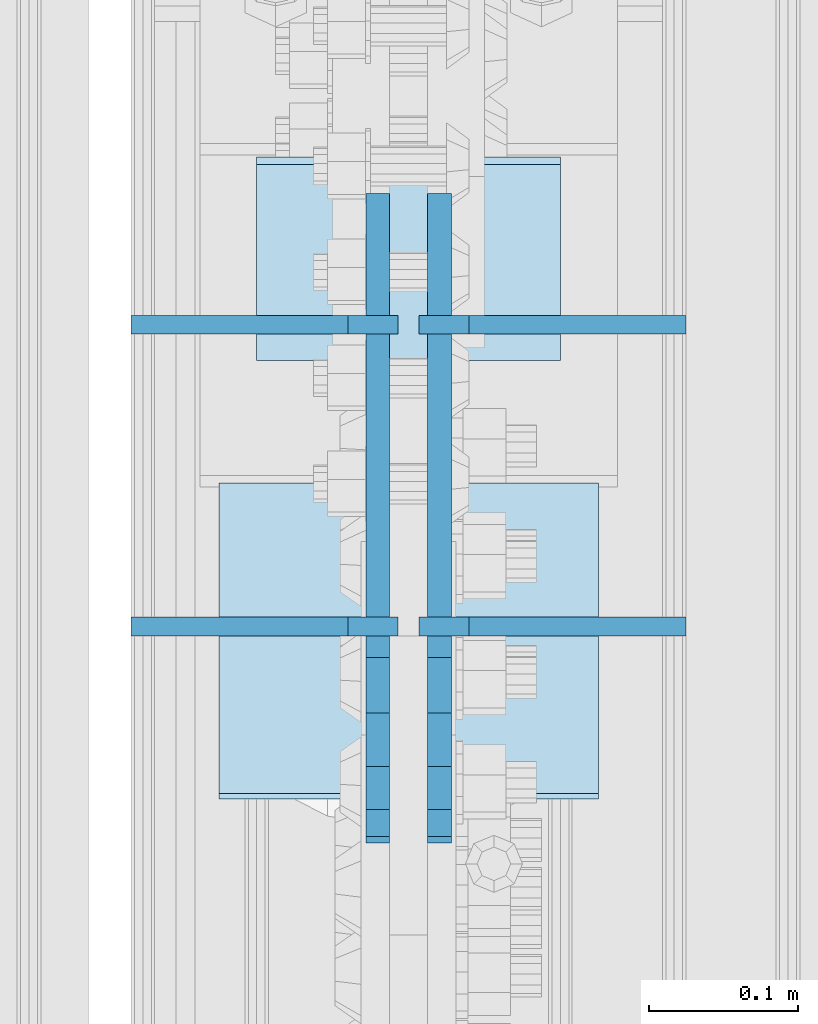
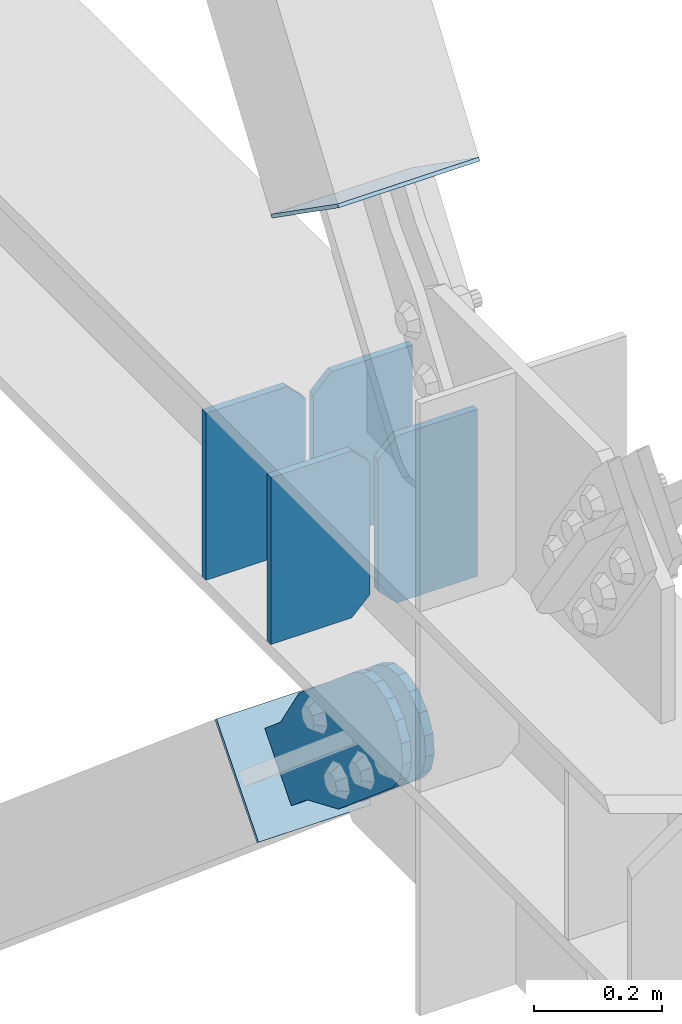
# One storey, part 3574 of 3843: 8 plates, 5 elements without a shape of their own.
"""IFC2X3 building model written with IfcOpenShell, lengths in millimetres."""

from ifc_helpers import new_model, si_unit, frame, origin_with_axes, place, context, subcontext, project, spatial, faceted_brep, material, type_object, element, aggregate, save


model = new_model("IFC2X3")

# Units and contexts
model_context = context("Model", 3, precision=1e-05, world=origin_with_axes())
body_context = subcontext(model_context, "Body", "Model", "MODEL_VIEW")
ifc_project = project(units=[si_unit("LENGTHUNIT", "METRE", prefix="MILLI"), si_unit("AREAUNIT", "SQUARE_METRE"), si_unit("VOLUMEUNIT", "CUBIC_METRE"), si_unit("MASSUNIT", "GRAM", prefix="KILO"), si_unit("TIMEUNIT", "SECOND"), si_unit("PLANEANGLEUNIT", "RADIAN"), si_unit("SOLIDANGLEUNIT", "STERADIAN"), si_unit("THERMODYNAMICTEMPERATUREUNIT", "DEGREE_CELSIUS"), si_unit("LUMINOUSINTENSITYUNIT", "LUMEN")], contexts=[model_context])

# Site, building, storey
site_placement = place(None, origin_with_axes())
site = spatial("IfcSite", under=ifc_project, at=site_placement, CompositionType="ELEMENT")
building_placement = place(site_placement, origin_with_axes())
building = spatial("IfcBuilding", under=site, at=building_placement, Name="Undefined", CompositionType="ELEMENT")
storey_placement = place(building_placement, origin_with_axes())
storey = spatial("IfcBuildingStorey", under=building, at=storey_placement, Name="Undefined", CompositionType="ELEMENT", Elevation=0.0)

# Assembly, plates
assembly_1_placement = place(storey_placement, origin_with_axes())
assembly_1 = element("IfcElementAssembly", 1, at=assembly_1_placement, inside=storey, Name="BEAM", AssemblyPlace="NOTDEFINED", PredefinedType="RIGID_FRAME")
ifc_material_1 = material(Name="STEEL/A572-50")
plate_type_1 = type_object("IfcPlateType", PredefinedType="NOTDEFINED")
plate_1_placement = place(assembly_1_placement, frame((85641.65625, 20972.8593750779, 34467.8), z_axis=(-1.0, 0.0, 0.0), x_axis=(0.0, 0.0, 1.0)))
plate_1 = element("IfcPlate", 2, at=plate_1_placement, type_object=plate_type_1, material=ifc_material_1, Name="CB_BEAM", context=body_context, shape_type="Brep", body=[
    faceted_brep([(0.0, -6.34999999999854, 33.3375015258789), (0.0, -6.34999999999854, 178.59375), (0.0, 6.34999999999854, 178.59375), (0.0, 6.34999999999854, 33.3375015258789), (317.499999999985, -6.34999999999854, 178.59375), (317.499999999985, 6.34999999999854, 178.59375), (317.499999999985, -6.34999999999854, 33.3375015258789), (317.499999999985, 6.34999999999854, 33.3375015258789), (284.162498474107, -6.34999999999854, 0.0), (284.162498474107, 6.34999999999854, 0.0), (33.3375015258789, -6.34999999999854, 0.0), (33.3375015258789, 6.34999999999854, 0.0)], [[[0, 1, 2, 3]], [[1, 4, 5, 2]], [[4, 6, 7, 5]], [[6, 8, 9, 7]], [[8, 10, 11, 9]], [[10, 0, 3, 11]], [[5, 7, 9, 11, 3, 2]], [[10, 8, 6, 4, 1, 0]]]),
])
plate_2_placement = place(assembly_1_placement, frame((85655.94375, 20972.8593750779, 34467.8), z_axis=(1.0, 0.0, 0.0), x_axis=(0.0, 0.0, 1.0)))
plate_2 = element("IfcPlate", 3, at=plate_2_placement, type_object=plate_type_1, material=ifc_material_1, Name="CB_BEAM", context=body_context, shape_type="Brep", body=[
    faceted_brep([(0.0, -6.34999999999854, 33.3375015258789), (0.0, -6.34999999999854, 178.59375), (0.0, 6.34999999999854, 178.59375), (0.0, 6.34999999999854, 33.3375015258789), (317.499999999985, -6.34999999999854, 178.59375), (317.499999999985, 6.34999999999854, 178.59375), (317.499999999985, -6.34999999999854, 33.3375015258789), (317.499999999985, 6.34999999999854, 33.3375015258789), (284.162498474107, -6.34999999999854, 0.0), (284.162498474107, 6.34999999999854, 0.0), (33.3375015258789, -6.34999999999854, 0.0), (33.3375015258789, 6.34999999999854, 0.0)], [[[0, 1, 2, 3]], [[1, 4, 5, 2]], [[4, 6, 7, 5]], [[6, 8, 9, 7]], [[8, 10, 11, 9]], [[10, 0, 3, 11]], [[5, 7, 9, 11, 3, 2]], [[10, 8, 6, 4, 1, 0]]]),
])
plate_3_placement = place(assembly_1_placement, frame((85641.65625, 20771.0484380779, 34467.8), z_axis=(-1.0, 0.0, 0.0), x_axis=(0.0, 0.0, 1.0)))
plate_3 = element("IfcPlate", 4, at=plate_3_placement, type_object=plate_type_1, material=ifc_material_1, Name="CB_BEAM", context=body_context, shape_type="Brep", body=[
    faceted_brep([(0.0, -6.34999999999854, 33.3375015258789), (0.0, -6.34999999999854, 178.59375), (0.0, 6.34999999999854, 178.59375), (0.0, 6.34999999999854, 33.3375015258789), (317.499999999985, -6.34999999999854, 178.59375), (317.499999999985, 6.34999999999854, 178.59375), (317.499999999985, -6.34999999999854, 33.3375015258789), (317.499999999985, 6.34999999999854, 33.3375015258789), (284.162498474107, -6.34999999999854, 0.0), (284.162498474107, 6.34999999999854, 0.0), (33.3375015258789, -6.34999999999854, 0.0), (33.3375015258789, 6.34999999999854, 0.0)], [[[0, 1, 2, 3]], [[1, 4, 5, 2]], [[4, 6, 7, 5]], [[6, 8, 9, 7]], [[8, 10, 11, 9]], [[10, 0, 3, 11]], [[5, 7, 9, 11, 3, 2]], [[10, 8, 6, 4, 1, 0]]]),
])
plate_4_placement = place(assembly_1_placement, frame((85655.94375, 20771.0484380779, 34467.8), z_axis=(1.0, 0.0, 0.0), x_axis=(0.0, 0.0, 1.0)))
plate_4 = element("IfcPlate", 5, at=plate_4_placement, type_object=plate_type_1, material=ifc_material_1, Name="CB_BEAM", context=body_context, shape_type="Brep", body=[
    faceted_brep([(0.0, -6.34999999999854, 33.3375015258789), (0.0, -6.34999999999854, 178.59375), (0.0, 6.34999999999854, 178.59375), (0.0, 6.34999999999854, 33.3375015258789), (317.499999999985, -6.34999999999854, 178.59375), (317.499999999985, 6.34999999999854, 178.59375), (317.499999999985, -6.34999999999854, 33.3375015258789), (317.499999999985, 6.34999999999854, 33.3375015258789), (284.162498474107, -6.34999999999854, 0.0), (284.162498474107, 6.34999999999854, 0.0), (33.3375015258789, -6.34999999999854, 0.0), (33.3375015258789, 6.34999999999854, 0.0)], [[[0, 1, 2, 3]], [[1, 4, 5, 2]], [[4, 6, 7, 5]], [[6, 8, 9, 7]], [[8, 10, 11, 9]], [[10, 0, 3, 11]], [[5, 7, 9, 11, 3, 2]], [[10, 8, 6, 4, 1, 0]]]),
])
aggregate(assembly_1, [plate_1, plate_2, plate_3, plate_4])

# Assembly, plate
assembly_2_placement = place(storey_placement, origin_with_axes())
assembly_2 = element("IfcElementAssembly", 6, at=assembly_2_placement, inside=storey, Name="Plate", AssemblyPlace="NOTDEFINED", PredefinedType="RIGID_FRAME")
ifc_material_2 = material(Name="STEEL/A36")
plate_type_2 = type_object("IfcPlateType", PredefinedType="NOTDEFINED")
plate_5_placement = place(assembly_2_placement, frame((85547.2, 20951.3934155147, 33948.7831890643), z_axis=(0.0, 0.645737502174365, 0.763559479206179), x_axis=(1.0, 0.0, 0.0)))
plate_5 = element("IfcPlate", 7, at=plate_5_placement, type_object=plate_type_2, material=ifc_material_2, Name="Plate", context=body_context, shape_type="Brep", body=[
    faceted_brep([(0.0, -3.17499999999927, 0.0), (0.0, -3.17500000043947, 203.200000001736), (0.0, 3.1749999995518, 203.200000001743), (0.0, 3.17499999999927, 0.0), (203.200000000012, -3.17500000043947, 203.200000001736), (203.200000000012, 3.1749999995518, 203.200000001743), (203.199996948242, -3.17499999999927, 0.0), (203.199996948242, 3.17499999999927, 0.0)], [[[0, 1, 2, 3]], [[1, 4, 5, 2]], [[4, 6, 7, 5]], [[6, 0, 3, 7]], [[5, 7, 3, 2]], [[6, 4, 1, 0]]]),
])
aggregate(assembly_2, [plate_5])

assembly_3_placement = place(storey_placement, origin_with_axes())
assembly_3 = element("IfcElementAssembly", 8, at=assembly_3_placement, inside=storey, Name="Plate", AssemblyPlace="NOTDEFINED", PredefinedType="RIGID_FRAME")
plate_type_3 = type_object("IfcPlateType", PredefinedType="NOTDEFINED")
plate_6_placement = place(assembly_3_placement, frame((85775.8, 20865.1681183892, 35200.9374941291), z_axis=(0.0, -0.818771907061984, 0.574118946043485), x_axis=(-1.0, 0.0, 0.0)))
plate_6 = element("IfcPlate", 9, at=plate_6_placement, type_object=plate_type_3, material=ifc_material_2, Name="Plate", context=body_context, shape_type="Brep", body=[
    faceted_brep([(0.0, -3.17499999999927, 0.0), (0.0, -3.17499999965185, 254.000000005151), (0.0, 3.17500000035216, 254.000000005166), (0.0, 3.17499999999927, 0.0), (254.0, -3.17499999965185, 254.000000005151), (254.0, 3.17500000035216, 254.000000005166), (254.0, -3.17500000000291, 0.0), (254.0, 3.17499999999927, 1.45519152283669e-11)], [[[0, 1, 2, 3]], [[1, 4, 5, 2]], [[4, 6, 7, 5]], [[6, 0, 3, 7]], [[5, 7, 3, 2]], [[6, 4, 1, 0]]]),
])
aggregate(assembly_3, [plate_6])

assembly_4_placement = place(storey_placement, origin_with_axes())
assembly_4 = element("IfcElementAssembly", 10, at=assembly_4_placement, inside=storey, AssemblyPlace="NOTDEFINED", PredefinedType="RIGID_FRAME")
plate_type_4 = type_object("IfcPlateType", PredefinedType="NOTDEFINED")
plate_7_placement = place(assembly_4_placement, frame((85628.1625, 21007.2581415508, 34118.0950855243), z_axis=(0.0, -0.645737502174364, -0.763559479206181), x_axis=(0.0, 0.76355947920618, -0.645737502174365)))
plate_7 = element("IfcPlate", 11, at=plate_7_placement, type_object=plate_type_4, material=ifc_material_2, context=body_context, shape_type="Brep", body=[
    faceted_brep([(0.0, -7.9375, 0.0), (-101.599999998451, -7.9375, -31.4963478657155), (-101.599999998451, 7.9375, -31.4963478657155), (0.0, 7.9375, 0.0), (-320.921138847057, -7.9375, -31.4963478655336), (-320.921138847057, 7.9375, -31.4963478655336), (-357.371735779619, -7.9375, -24.2458733372187), (-357.371735779619, 7.9375, -24.2458733372187), (-388.273059754701, -7.9375, -3.59826877355954), (-388.273059754701, 7.9375, -3.59826877355954), (-408.92066431832, -7.9375, 27.3030552016353), (-408.92066431832, 7.9375, 27.3030552016353), (-416.171138846671, -7.9375, 63.7536521347356), (-416.171138846671, 7.9375, 63.7536521347356), (-408.920664318482, -7.9375, 100.204249067661), (-408.920664318482, 7.9375, 100.204249067661), (-388.273059754884, -7.9375, 131.105573043053), (-388.273059754884, 7.9375, 131.105573043053), (-357.371735779699, -7.9375, 151.753177606828), (-357.371735779699, 7.9375, 151.753177606828), (-320.921138848337, -7.9375, 159.003652135143), (-320.921138848337, 7.9375, 159.003652135143), (-101.599999999054, -7.9375, 159.003652134947), (-101.599999999054, 7.9375, 159.003652134947), (-4.01087163481861e-10, -7.9375, 127.507304269042), (-4.01087163481861e-10, 7.9375, 127.507304269042), (69.8499999986043, -7.9375, 127.507304268976), (69.8499999986043, 7.9375, 127.507304268976), (69.850000000486, -7.9375, 2.91038304567337e-11), (69.850000000486, 7.9375, 2.91038304567337e-11)], [[[0, 1, 2, 3]], [[1, 4, 5, 2]], [[4, 6, 7, 5]], [[6, 8, 9, 7]], [[8, 10, 11, 9]], [[10, 12, 13, 11]], [[12, 14, 15, 13]], [[14, 16, 17, 15]], [[16, 18, 19, 17]], [[18, 20, 21, 19]], [[20, 22, 23, 21]], [[22, 24, 25, 23]], [[24, 26, 27, 25]], [[26, 28, 29, 27]], [[28, 0, 3, 29]], [[5, 7, 9, 11, 13, 15, 17, 19, 21, 23, 25, 27, 29, 3, 2]], [[28, 26, 24, 22, 20, 18, 16, 14, 12, 10, 8, 6, 4, 1, 0]]]),
])
aggregate(assembly_4, [plate_7])

assembly_5_placement = place(storey_placement, origin_with_axes())
assembly_5 = element("IfcElementAssembly", 12, at=assembly_5_placement, inside=storey, AssemblyPlace="NOTDEFINED", PredefinedType="RIGID_FRAME")
plate_8_placement = place(assembly_5_placement, frame((85669.4375, 21007.2581415508, 34118.0950855243), z_axis=(0.0, -0.645737502174364, -0.763559479206181), x_axis=(0.0, 0.76355947920618, -0.645737502174365)))
plate_8 = element("IfcPlate", 13, at=plate_8_placement, type_object=plate_type_4, material=ifc_material_2, context=body_context, shape_type="Brep", body=[
    faceted_brep([(0.0, -7.9375, 0.0), (-101.599999998451, -7.9375, -31.4963478657155), (-101.599999998451, 7.9375, -31.4963478657155), (0.0, 7.9375, 0.0), (-320.921138847057, -7.9375, -31.4963478655336), (-320.921138847057, 7.9375, -31.4963478655336), (-357.371735779619, -7.9375, -24.2458733372187), (-357.371735779619, 7.9375, -24.2458733372187), (-388.273059754701, -7.9375, -3.59826877355954), (-388.273059754701, 7.9375, -3.59826877355954), (-408.92066431832, -7.9375, 27.3030552016353), (-408.92066431832, 7.9375, 27.3030552016353), (-416.171138846671, -7.9375, 63.7536521347356), (-416.171138846671, 7.9375, 63.7536521347356), (-408.920664318482, -7.9375, 100.204249067661), (-408.920664318482, 7.9375, 100.204249067661), (-388.273059754884, -7.9375, 131.105573043053), (-388.273059754884, 7.9375, 131.105573043053), (-357.371735779699, -7.9375, 151.753177606828), (-357.371735779699, 7.9375, 151.753177606828), (-320.921138848337, -7.9375, 159.003652135143), (-320.921138848337, 7.9375, 159.003652135143), (-101.599999999054, -7.9375, 159.003652134947), (-101.599999999054, 7.9375, 159.003652134947), (-4.01087163481861e-10, -7.9375, 127.507304269042), (-4.01087163481861e-10, 7.9375, 127.507304269042), (69.8499999986043, -7.9375, 127.507304268976), (69.8499999986043, 7.9375, 127.507304268976), (69.850000000486, -7.9375, 2.91038304567337e-11), (69.850000000486, 7.9375, 2.91038304567337e-11)], [[[0, 1, 2, 3]], [[1, 4, 5, 2]], [[4, 6, 7, 5]], [[6, 8, 9, 7]], [[8, 10, 11, 9]], [[10, 12, 13, 11]], [[12, 14, 15, 13]], [[14, 16, 17, 15]], [[16, 18, 19, 17]], [[18, 20, 21, 19]], [[20, 22, 23, 21]], [[22, 24, 25, 23]], [[24, 26, 27, 25]], [[26, 28, 29, 27]], [[28, 0, 3, 29]], [[5, 7, 9, 11, 13, 15, 17, 19, 21, 23, 25, 27, 29, 3, 2]], [[28, 26, 24, 22, 20, 18, 16, 14, 12, 10, 8, 6, 4, 1, 0]]]),
])
aggregate(assembly_5, [plate_8])

save(model, "model.ifc")
